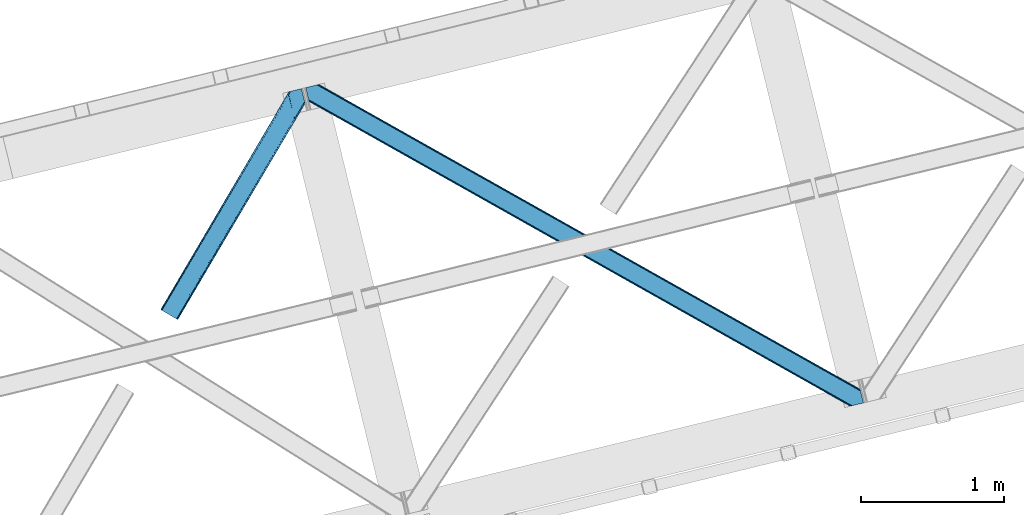
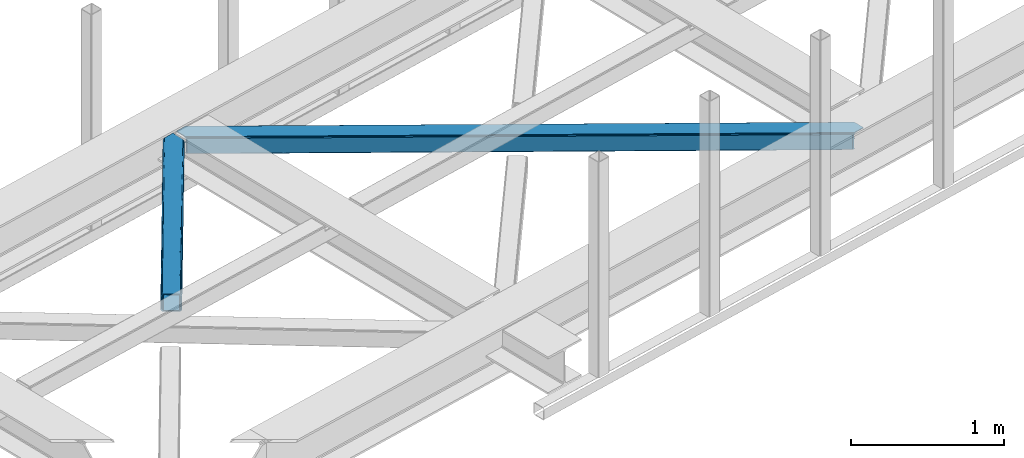
# One storey, part 26 of 66: 2 members.
"""IFC4 building model written with IfcOpenShell, lengths in millimetres."""

from ifc_helpers import new_model, entity, si_unit, converted_unit, derived_unit, direction, frame, origin, place, context, subcontext, project, spatial, triangles, type_object, element, save


model = new_model("IFC4")

# Units and contexts
model_context = context("Model", 3, precision=0.01, world=origin(), true_north=direction((6.12303176911189e-17, 1.0)))
plan_context = context("Plan", 3, precision=0.01, world=origin(), true_north=direction((6.12303176911189e-17, 1.0)))
body_context = subcontext(model_context, "Body", "Model", "MODEL_VIEW")
ifc_project = project(units=[si_unit("LENGTHUNIT", "METRE", prefix="MILLI"), si_unit("AREAUNIT", "SQUARE_METRE"), si_unit("VOLUMEUNIT", "CUBIC_METRE"), converted_unit("PLANEANGLEUNIT", "DEGREE", entity("IfcRatioMeasure", 0.0174532925199433), si_unit("PLANEANGLEUNIT", "RADIAN"), dimensions=[0, 0, 0, 0, 0, 0, 0]), si_unit("MASSUNIT", "GRAM", prefix="KILO"), derived_unit("MASSDENSITYUNIT", [(si_unit("MASSUNIT", "GRAM", prefix="KILO"), 1), (si_unit("LENGTHUNIT", "METRE"), -3)]), derived_unit("MOMENTOFINERTIAUNIT", [(si_unit("LENGTHUNIT", "METRE"), 4)]), si_unit("TIMEUNIT", "SECOND"), si_unit("FREQUENCYUNIT", "HERTZ"), si_unit("THERMODYNAMICTEMPERATUREUNIT", "DEGREE_CELSIUS"), derived_unit("THERMALTRANSMITTANCEUNIT", [(si_unit("MASSUNIT", "GRAM", prefix="KILO"), 1), (si_unit("THERMODYNAMICTEMPERATUREUNIT", "KELVIN"), -1), (si_unit("TIMEUNIT", "SECOND"), -3)]), derived_unit("VOLUMETRICFLOWRATEUNIT", [(si_unit("LENGTHUNIT", "METRE"), 3), (si_unit("TIMEUNIT", "SECOND"), -1)]), derived_unit("MASSFLOWRATEUNIT", [(si_unit("MASSUNIT", "GRAM", prefix="KILO"), 1), (si_unit("TIMEUNIT", "SECOND"), -1)]), derived_unit("ROTATIONALFREQUENCYUNIT", [(si_unit("TIMEUNIT", "SECOND"), -1)]), si_unit("ELECTRICCURRENTUNIT", "AMPERE"), si_unit("ELECTRICVOLTAGEUNIT", "VOLT"), si_unit("POWERUNIT", "WATT"), si_unit("FORCEUNIT", "NEWTON", prefix="KILO"), si_unit("ILLUMINANCEUNIT", "LUX"), si_unit("LUMINOUSFLUXUNIT", "LUMEN"), si_unit("LUMINOUSINTENSITYUNIT", "CANDELA"), derived_unit("USERDEFINED", [(si_unit("MASSUNIT", "GRAM", prefix="KILO"), -1), (si_unit("LENGTHUNIT", "METRE"), -2), (si_unit("TIMEUNIT", "SECOND"), 3), (si_unit("LUMINOUSFLUXUNIT", "LUMEN"), 1)]), derived_unit("LINEARVELOCITYUNIT", [(si_unit("LENGTHUNIT", "METRE"), 1), (si_unit("TIMEUNIT", "SECOND"), -1)]), si_unit("PRESSUREUNIT", "PASCAL"), derived_unit("USERDEFINED", [(si_unit("LENGTHUNIT", "METRE"), -2), (si_unit("MASSUNIT", "GRAM", prefix="KILO"), 1), (si_unit("TIMEUNIT", "SECOND"), -2)]), derived_unit("LINEARFORCEUNIT", [(si_unit("MASSUNIT", "GRAM", prefix="KILO"), 1), (si_unit("LENGTHUNIT", "METRE"), 1), (si_unit("TIMEUNIT", "SECOND"), -2), (si_unit("LENGTHUNIT", "METRE"), -1)]), derived_unit("PLANARFORCEUNIT", [(si_unit("MASSUNIT", "GRAM", prefix="KILO"), 1), (si_unit("LENGTHUNIT", "METRE"), 1), (si_unit("TIMEUNIT", "SECOND"), -2), (si_unit("LENGTHUNIT", "METRE"), -2)])], contexts=[model_context, plan_context])

# Site, building, storey
site_placement = place(None, origin())
site = spatial("IfcSite", under=ifc_project, at=site_placement, CompositionType="ELEMENT")
building_placement = place(site_placement, origin())
building = spatial("IfcBuilding", under=site, at=building_placement, CompositionType="ELEMENT")
storey_placement = place(building_placement, frame((0.0, 0.0, 19800.0)))
storey = spatial("IfcBuildingStorey", under=building, at=storey_placement, Name="06", CompositionType="ELEMENT", Elevation=19800.0)

# Members
member_type_1 = type_object("IfcMemberType", PredefinedType="BRACE")
member_1_placement = place(storey_placement, frame((-49332.88, 6520.94, 3824.0)))
element("IfcMember", 1, at=member_1_placement, inside=storey, type_object=member_type_1, ObjectType="Steel Horizontal Brace", PredefinedType="BRACE", context=body_context, shape_type="Tessellation", body=[
    triangles([(3809.33957519531, 0.0, 122.499499511719), (3811.23713378907, 0.462181091308594, 129.196765136719), (23.4590332031294, 2133.5476776123, 129.196765136719), (23.8915649414048, 2131.77569274902, 122.499499511719), (3816.63215332032, 1.7772171020506, 134.87548828125), (22.2265502929731, 2138.59446258545, 134.87548828125), (3824.70607910156, 3.74512023925763, 138.668280029298), (20.3894531250044, 2146.14690856934, 138.668280029298), (3834.23107910156, 6.06707153320258, 140.00075683594), (18.2174926757798, 2155.05566711426, 140.00075683594), (1916.9806640625, 1065.68146362305, 17.5012573242202), (2556.1183959961, 705.752851867675, 17.5012573242202), (3195.25147705078, 345.824240112304, 17.5012573242202), (3809.33957519531, 0.0, 17.5012573242202), (1277.84758300782, 1425.61065673828, 17.5012573242202), (638.709851074222, 1785.53868713379, 17.5012573242202), (23.8915649414048, 2131.77569274902, 17.5012573242202), (3885.46051025391, 97.721360778808, 140.00075683594), (3903.67800292969, 22.9951080322262, 140.00075683594), (69.4469238281235, 2246.70995635986, 140.00075683594), (0.0, 2229.78191986084, 140.00075683594), (3883.28854980469, 106.63011932373, 138.668280029298), (78.971923828125, 2249.03190765381, 138.668280029298), (3881.44680175781, 114.182565307617, 134.87548828125), (87.0458496093779, 2251.00039215088, 134.87548828125), (3880.21896972656, 119.229350280762, 129.196765136719), (92.4408691406279, 2252.31542816162, 129.196765136719), (3879.78643798828, 121.001335144043, 122.499499511719), (94.3384277343794, 2252.77760925293, 122.499499511719), (3265.41928710938, 466.982542419433, 17.5012573242202), (3879.78643798828, 121.001335144043, 17.5012573242202), (2626.2955078125, 826.905340576172, 17.5012573242202), (1987.17172851563, 1186.82813873291, 17.5012573242202), (708.924169921876, 1906.67315368652, 17.5012573242202), (94.3384277343794, 2252.77760925293, 17.5012573242202), (1348.04794921875, 1546.75093688965, 17.5012573242202), (77.0929687500029, 2248.57321472168, 127.873590087893), (69.0143920898481, 2246.60473022461, 131.668707275392), (82.4879882812529, 2249.88883209228, 122.197192382813), (59.4893920898467, 2244.28277893066, 133.001184082033), (0.0, 2229.78191986084, 133.001184082033), (84.3808959960952, 2250.35043182373, 115.499926757813), (84.3808959960952, 2250.35043182373, 24.5008300781265), (82.4879882812529, 2249.88883209228, 17.8035644531265), (92.0548461914077, 2252.22124786377, 10.8691040039084), (91.5851074218735, 2252.10613861084, 9.49942016601563), (77.0929687500029, 2248.57321472168, 12.1248413085959), (72.3118652343765, 2247.40816955566, 9.49942016601563), (1983.48823242188, 1180.86745605469, 24.5008300781265), (3882.05606689453, 111.689694213866, 115.499926757813), (2626.78850097657, 818.593057250976, 24.5008300781265), (3270.08876953125, 456.319239807129, 24.5008300781265), (3882.05606689453, 111.689694213866, 24.5008300781265), (1340.18796386719, 1543.14127349854, 24.5008300781265), (696.892346191409, 1905.41509094238, 24.5008300781265), (3882.48859863282, 109.917127990722, 122.197192382813), (3883.71643066406, 104.870924377441, 127.873590087893), (3885.55817871094, 97.318478393554, 131.668707275392), (3887.73013916016, 88.4097198486324, 133.001184082033), (3883.71643066406, 104.870924377441, 12.1248413085959), (3885.41865234375, 97.8998382568352, 8.52041015625218), (3880.59104003906, 117.702699279785, 8.52041015625218), (3903.67800292969, 22.9951080322262, 133.001184082033), (3882.48859863282, 109.917127990722, 17.8035644531265), (3880.37244873047, 118.590435791015, 10.9365417480476), (3844.18861083985, 8.4942489624018, 133.001184082033), (15.9478637695356, 2164.3678894043, 133.001184082033), (3834.66361083985, 6.17229766845685, 131.668707275392), (18.1198242187529, 2155.45854949951, 131.668707275392), (3826.58503417969, 4.20381317138617, 127.873590087893), (19.9569213867217, 2147.90610351563, 127.873590087893), (3821.19001464844, 2.88877716064417, 122.197192382813), (21.1894042968779, 2142.85989990234, 122.197192382813), (3819.2971069336, 2.42717742919922, 115.499926757813), (21.6219360351606, 2141.08791503906, 115.499926757813), (3208.50183105469, 346.39571685791, 24.5008300781265), (3819.2971069336, 2.42717742919922, 24.5008300781265), (2565.16435546875, 708.690463256836, 24.5008300781265), (1921.82687988281, 1070.98520965576, 24.5008300781265), (635.156579589842, 1795.57528381348, 24.5008300781265), (21.6219360351606, 2141.08791503906, 24.5008300781265), (1278.49405517578, 1433.28053741455, 24.5008300781265), (21.1894042968779, 2142.85989990234, 17.8035644531265), (19.9569213867217, 2147.90610351563, 12.1248413085959), (23.263696289061, 2134.3505355835, 9.49942016601563), (23.3706665039063, 2133.90986480713, 10.8691040039084), (18.8686157226548, 2152.37676086426, 9.49942016601563), (3821.19001464844, 2.88877716064417, 17.8035644531265), (3811.91616210937, 0.628450012206486, 10.9365417480476), (3812.86494140625, 0.859831237792605, 8.52041015625218), (3826.58503417969, 4.20381317138617, 12.1248413085959), (3834.04039306641, 6.02056274414008, 8.52041015625218), (190.667431640628, 2055.62743377685, 9.49942016601563), (195.062512207034, 2037.60120849609, 9.49942016601563), (196.076403808598, 2037.6692276001, 8.49948120117188), (196.057800292969, 2037.42389373779, 8.8831787109375), (191.290649414063, 2056.67097473144, 8.85294799804615), (195.732238769531, 2037.48144836426, 9.08316650390771), (191.346459960936, 2055.82567749023, 9.20641479492406), (195.388073730472, 2037.54365386963, 9.29943237304906), (191.006945800786, 2055.72684631348, 9.35291748046802), (191.239489746098, 2057.51627197266, 8.49948120117188), (150.921020507813, 2218.69073638916, 9.49942016601563), (155.316101074219, 2200.6645111084, 9.49942016601563), (151.251232910159, 2218.34947814941, 9.25757446289208), (155.813745117186, 2200.23721160889, 9.42500610351635), (151.60469970703, 2217.98496551514, 8.99945068359375), (156.250927734378, 2199.30529174805, 9.11804809570458), (151.962817382817, 2217.619871521, 8.74132690429906), (156.692761230472, 2198.36407012939, 8.80643920898365), (152.293029785156, 2217.27861328125, 8.49948120117188), (157.129943847656, 2197.43156890869, 8.49948120117188), (3713.61983642578, 194.649165344238, 8.52041015625218), (3708.7922241211, 214.452026367188, 8.52041015625218), (3713.26636962891, 194.529986572265, 8.40181274414135), (3708.39689941407, 214.570623779297, 8.37390747070458), (3713.06173095703, 194.460223388672, 8.3320495605476), (3708.00622558594, 214.689221191406, 8.22740478515698), (3707.90390625, 214.477606201172, 7.87393798828271), (3713.112890625, 193.949789428711, 8.19484863281468), (3707.80623779297, 214.265991210938, 7.52047119140843), (3713.23846435547, 192.705679321289, 7.85765991211156), (3713.36403808594, 191.465057373047, 7.52047119140843), (3264.76351318359, 465.821566772461, 10.8039916992202), (3262.90316162109, 462.516535949707, 5.12526855468968), (3260.11728515625, 457.569744873046, 1.33247680664135), (3708.58293457032, 211.088278198242, 5.59500732422021), (708.268395996092, 1905.51275939941, 10.8039916992202), (706.408044433592, 1902.2071472168, 5.12526855468968), (153.148791503911, 2213.77475738525, 5.12526855468968), (703.622167968751, 1897.26035614014, 1.33247680664135), (154.990539550781, 2206.22231140137, 1.33247680664135), (700.333996582034, 1891.42524719238, 0.0), (157.162499999999, 2197.31355285644, 0.0), (3710.29445800781, 204.051498413086, 1.33247680664135), (3712.46641845704, 195.142739868164, 0.0), (3256.83376464844, 451.73405456543, 0.0), (2625.63973388672, 825.744364929199, 10.8039916992202), (1986.51595458984, 1185.66716308594, 10.8039916992202), (1347.39217529297, 1545.58996124268, 10.8039916992202), (2623.77938232422, 822.439334106445, 5.12526855468968), (1984.65560302734, 1182.36213226318, 5.12526855468968), (1345.53182373047, 1542.28434906006, 5.12526855468968), (2620.99350585938, 817.492543029785, 1.33247680664135), (1981.8697265625, 1177.41475982666, 1.33247680664135), (1342.74594726563, 1537.3375579834, 1.33247680664135), (2617.70998535156, 811.656852722168, 0.0), (1978.58155517578, 1171.57965087891, 0.0), (1339.45777587891, 1531.50244903564, 0.0), (3746.51550292969, 55.4634750366204, 0.0), (3203.83699951172, 361.072146606445, 0.0), (2564.70391845703, 721.000758361816, 0.0), (1925.57083740235, 1080.92995147705, 0.0), (1286.43310546875, 1440.85856323242, 0.0), (647.300024414064, 1800.78717498779, 0.0), (191.206933593749, 2057.6342880249, 0.0), (3195.90725097656, 346.984634399414, 10.8039916992202), (639.365624999999, 1786.69966278076, 10.8039916992202), (641.225976562499, 1790.00527496338, 5.12526855468968), (195.220642089844, 2041.17308349609, 5.12526855468968), (3197.76760253906, 350.290246582031, 5.12526855468968), (3200.55347900391, 355.237037658691, 1.33247680664135), (3748.6874633789, 46.5547164916989, 1.33247680664135), (3752.58024902344, 34.8100845336912, 8.52041015625218), (3750.40363769532, 39.517936706543, 5.59500732422021), (3751.18033447266, 36.3402236938473, 7.52047119140843), (3752.24073486328, 35.1804107666012, 8.278564453125), (644.011853027347, 1794.95206604004, 1.33247680664135), (193.378894042973, 2048.72552947998, 1.33247680664135), (2561.41574707031, 715.165649414063, 1.33247680664135), (1922.28266601563, 1075.09426116943, 1.33247680664135), (1283.14958496094, 1435.02345428467, 1.33247680664135), (2558.62987060547, 710.218858337402, 5.12526855468968), (1919.49678955078, 1070.14747009277, 5.12526855468968), (1280.36370849609, 1430.07666320801, 5.12526855468968), (2556.76951904297, 706.913246154785, 10.8039916992202), (1917.63643798828, 1066.84243927002, 10.8039916992202), (1278.49870605469, 1426.77105102539, 10.8039916992202), (3745.61788330078, 59.1411575317379, 7.52047119140843), (3746.13413085938, 57.3430114746088, 7.90416870117406), (3746.6736328125, 56.4360900878901, 8.10880737304615), (3747.30150146485, 55.3762710571282, 8.34832763671875), (3747.75263671875, 54.6129455566406, 8.52041015625218), (3211.01795654297, 350.861723327636, 12.1248413085959), (3217.08735351563, 361.644204711914, 6.99957275390625), (3213.80383300781, 355.808514404296, 8.3320495605476), (3744.24587402344, 64.7751159667969, 6.99957275390625), (643.742102050783, 1810.82377166748, 6.99957275390625), (188.937304687504, 2066.94651031494, 6.99957275390625), (637.672705078126, 1800.0412902832, 12.1248413085959), (640.458581542967, 1804.98866271973, 8.3320495605476), (635.807702636717, 1796.73625946045, 17.8035644531265), (3209.15760498047, 347.556111145019, 17.8035644531265), (2565.82012939453, 709.851438903808, 17.8035644531265), (1922.4826538086, 1072.14618530273, 17.8035644531265), (1279.14517822266, 1434.44093170166, 17.8035644531265), (2567.68048095703, 713.156469726562, 12.1248413085959), (1924.3430053711, 1075.45179748535, 12.1248413085959), (1281.00552978516, 1437.74654388428, 12.1248413085959), (2570.46635742188, 718.103842163086, 8.3320495605476), (1927.12888183594, 1080.39858856201, 8.3320495605476), (1283.79140625, 1442.69333496094, 8.3320495605476), (2573.7545288086, 723.938951110839, 6.99957275390625), (1930.41705322266, 1086.23369750977, 6.99957275390625), (1287.07957763672, 1448.52902526855, 6.99957275390625), (694.376220703125, 1900.94908447266, 12.1248413085959), (691.590344238284, 1896.002293396, 8.3320495605476), (157.264819335942, 2196.88450927734, 8.41343994140698), (159.43212890625, 2188.00191192627, 6.99957275390625), (3261.50324707032, 441.070751953124, 6.99957275390625), (3264.78676757812, 446.905860900879, 8.3320495605476), (3714.73604736328, 185.831098937988, 6.99957275390625), (3267.57264404297, 451.853233337402, 12.1248413085959), (688.302172851567, 1890.16718444824, 6.99957275390625), (696.236572265625, 1904.25469665527, 17.8035644531265), (3269.43299560547, 455.158264160156, 17.8035644531265), (2618.20297851563, 803.344569396972, 6.99957275390625), (2621.48649902344, 809.179678344726, 8.3320495605476), (1978.18623046875, 1171.45407714844, 8.3320495605476), (1974.90270996094, 1165.61896820068, 6.99957275390625), (1334.89061279297, 1533.72847595215, 8.3320495605476), (1331.60244140625, 1527.89336700439, 6.99957275390625), (2624.27237548828, 814.12705078125, 12.1248413085959), (1980.9767578125, 1176.40144958496, 12.1248413085959), (1337.67648925781, 1538.67526702881, 12.1248413085959), (2626.13272705078, 817.432081604004, 17.8035644531265), (1982.837109375, 1179.70648040771, 17.8035644531265), (1339.53684082031, 1541.98087921143, 17.8035644531265)], [[1, 2, 3], [3, 4, 1], [2, 5, 6], [6, 3, 2], [5, 7, 8], [8, 6, 5], [7, 9, 10], [10, 8, 7], [11, 1, 4], [1, 12, 13], [11, 12, 1], [13, 14, 1], [15, 4, 16], [4, 15, 11], [17, 16, 4], [9, 18, 10], [9, 19, 18], [20, 10, 18], [21, 10, 20], [18, 22, 23], [23, 20, 18], [22, 24, 25], [25, 23, 22], [24, 26, 27], [27, 25, 24], [26, 28, 29], [29, 27, 26], [30, 28, 31], [28, 30, 32], [28, 33, 29], [33, 28, 32], [34, 35, 29], [36, 29, 33], [29, 36, 34], [37, 38, 23], [25, 37, 23], [25, 27, 39], [37, 25, 39], [39, 27, 29], [38, 20, 23], [21, 40, 41], [21, 20, 40], [38, 40, 20], [39, 29, 42], [43, 35, 44], [29, 43, 42], [35, 45, 44], [29, 35, 43], [46, 44, 45], [47, 44, 46], [48, 47, 46], [49, 50, 42], [50, 51, 52], [49, 51, 50], [52, 53, 50], [54, 42, 55], [42, 54, 49], [43, 55, 42], [50, 56, 42], [39, 42, 56], [56, 57, 39], [37, 39, 57], [57, 58, 37], [38, 37, 58], [58, 59, 38], [40, 38, 59], [57, 24, 22], [60, 61, 62], [24, 57, 56], [58, 57, 22], [58, 18, 59], [19, 59, 18], [59, 19, 63], [58, 22, 18], [31, 28, 53], [62, 64, 60], [64, 31, 53], [65, 64, 62], [65, 31, 64], [28, 50, 53], [56, 26, 24], [28, 26, 56], [50, 28, 56], [59, 66, 67], [66, 59, 63], [67, 40, 59], [41, 40, 67], [66, 68, 67], [69, 67, 68], [68, 70, 69], [71, 69, 70], [70, 72, 71], [73, 71, 72], [72, 74, 73], [75, 73, 74], [76, 74, 77], [74, 76, 78], [74, 79, 75], [79, 74, 78], [80, 81, 75], [82, 75, 79], [75, 82, 80], [73, 6, 71], [75, 81, 4], [3, 73, 4], [73, 3, 6], [73, 75, 4], [81, 17, 4], [83, 84, 85], [85, 86, 83], [86, 17, 83], [81, 83, 17], [67, 10, 21], [10, 69, 8], [69, 10, 67], [21, 41, 67], [69, 71, 8], [87, 85, 84], [8, 71, 6], [70, 68, 7], [5, 70, 7], [5, 2, 72], [70, 5, 72], [72, 2, 1], [68, 9, 7], [19, 66, 63], [19, 9, 66], [68, 66, 9], [72, 1, 74], [77, 14, 88], [1, 77, 74], [14, 89, 88], [1, 14, 77], [90, 88, 89], [91, 88, 90], [92, 91, 90], [93, 94, 85], [85, 87, 93], [95, 96, 97], [96, 98, 99], [99, 98, 100], [101, 100, 94], [94, 93, 101], [100, 101, 99], [99, 97, 96], [97, 102, 95], [103, 104, 46], [48, 46, 104], [105, 106, 104], [107, 108, 106], [109, 110, 108], [111, 112, 110], [110, 109, 111], [108, 107, 109], [106, 105, 107], [104, 103, 105], [62, 61, 113], [113, 114, 62], [115, 116, 114], [117, 118, 116], [116, 115, 117], [119, 118, 120], [121, 119, 122], [122, 123, 121], [120, 122, 119], [117, 120, 118], [114, 113, 115], [124, 30, 31], [125, 124, 118], [118, 119, 125], [119, 121, 125], [124, 65, 114], [114, 116, 124], [116, 118, 124], [65, 62, 114], [126, 125, 127], [45, 128, 103], [128, 129, 130], [130, 111, 128], [128, 109, 107], [109, 128, 111], [128, 105, 103], [105, 128, 107], [128, 45, 35], [35, 34, 128], [103, 46, 45], [129, 131, 132], [132, 130, 129], [131, 133, 134], [134, 132, 131], [135, 136, 137], [137, 126, 135], [127, 135, 126], [121, 127, 125], [31, 65, 124], [30, 124, 138], [138, 32, 30], [32, 138, 139], [139, 33, 32], [33, 139, 36], [140, 36, 139], [36, 140, 34], [128, 34, 140], [124, 125, 138], [141, 138, 125], [138, 141, 139], [142, 139, 141], [139, 142, 143], [143, 140, 139], [140, 143, 129], [129, 128, 140], [125, 126, 144], [144, 141, 125], [141, 144, 145], [145, 142, 141], [142, 145, 143], [146, 143, 145], [143, 146, 129], [131, 129, 146], [126, 137, 147], [147, 144, 126], [144, 147, 148], [148, 145, 144], [145, 148, 149], [149, 146, 145], [146, 149, 131], [133, 131, 149], [136, 150, 151], [137, 151, 147], [151, 137, 136], [148, 152, 153], [152, 147, 151], [148, 147, 152], [133, 149, 154], [153, 149, 148], [149, 153, 154], [155, 133, 154], [156, 133, 155], [134, 133, 156], [157, 89, 14], [158, 16, 17], [159, 96, 95], [158, 86, 94], [94, 159, 158], [94, 98, 159], [86, 85, 94], [95, 160, 159], [161, 162, 163], [89, 157, 164], [157, 161, 165], [165, 166, 157], [167, 164, 157], [157, 166, 167], [164, 90, 89], [163, 165, 161], [150, 163, 162], [162, 151, 150], [155, 168, 169], [169, 156, 155], [168, 159, 160], [160, 169, 168], [17, 86, 158], [14, 13, 157], [151, 162, 170], [170, 152, 151], [152, 170, 153], [171, 153, 170], [153, 171, 154], [172, 154, 171], [154, 172, 155], [168, 155, 172], [162, 161, 170], [173, 170, 161], [170, 173, 171], [174, 171, 173], [171, 174, 172], [175, 172, 174], [172, 175, 168], [159, 168, 175], [161, 157, 176], [176, 173, 161], [173, 176, 177], [177, 174, 173], [174, 177, 178], [178, 175, 174], [175, 178, 158], [158, 159, 175], [157, 13, 176], [12, 176, 13], [176, 12, 177], [11, 177, 12], [177, 11, 178], [15, 178, 11], [178, 15, 158], [16, 158, 15], [166, 179, 180], [166, 180, 181], [167, 181, 182], [167, 182, 183], [92, 90, 183], [164, 183, 90], [184, 183, 182], [91, 92, 183], [183, 184, 91], [185, 180, 179], [182, 185, 186], [182, 181, 185], [180, 185, 181], [179, 187, 185], [188, 189, 102], [93, 84, 190], [93, 87, 84], [102, 190, 191], [190, 102, 97], [97, 99, 190], [80, 192, 81], [83, 81, 192], [192, 190, 83], [84, 83, 190], [102, 191, 188], [182, 186, 184], [88, 91, 184], [184, 193, 88], [77, 88, 193], [193, 76, 77], [76, 193, 194], [194, 78, 76], [78, 194, 79], [195, 79, 194], [79, 195, 82], [196, 82, 195], [82, 196, 192], [192, 80, 82], [193, 184, 194], [197, 194, 184], [194, 197, 195], [198, 195, 197], [195, 198, 199], [199, 196, 195], [196, 199, 190], [190, 192, 196], [184, 186, 200], [200, 197, 184], [197, 200, 201], [201, 198, 197], [198, 201, 202], [202, 199, 198], [199, 202, 191], [191, 190, 199], [186, 185, 203], [203, 200, 186], [200, 203, 201], [204, 201, 203], [201, 204, 202], [205, 202, 204], [202, 205, 191], [188, 191, 205], [206, 106, 108], [108, 207, 206], [108, 110, 207], [110, 208, 207], [104, 206, 47], [47, 48, 104], [207, 208, 209], [210, 123, 122], [122, 211, 210], [122, 117, 211], [210, 212, 123], [213, 211, 117], [61, 60, 113], [213, 113, 60], [209, 214, 207], [206, 215, 44], [44, 47, 206], [215, 55, 43], [43, 44, 215], [64, 53, 216], [52, 216, 53], [60, 64, 213], [216, 213, 64], [210, 211, 217], [218, 217, 211], [217, 218, 219], [219, 220, 217], [220, 219, 221], [221, 222, 220], [222, 221, 207], [207, 214, 222], [211, 213, 223], [223, 218, 211], [218, 223, 224], [224, 219, 218], [219, 224, 221], [225, 221, 224], [221, 225, 207], [206, 207, 225], [213, 216, 223], [226, 223, 216], [223, 226, 224], [227, 224, 226], [224, 227, 225], [228, 225, 227], [225, 228, 215], [215, 206, 225], [216, 52, 51], [51, 226, 216], [226, 51, 227], [49, 227, 51], [227, 49, 228], [54, 228, 49], [228, 54, 215], [55, 215, 54], [209, 134, 189], [132, 208, 130], [208, 132, 134], [130, 208, 111], [134, 209, 208], [189, 134, 156], [169, 102, 156], [102, 169, 160], [156, 102, 189], [160, 95, 102], [136, 212, 187], [123, 127, 121], [136, 123, 212], [123, 135, 127], [123, 136, 135], [150, 136, 187], [179, 150, 187], [165, 179, 166], [179, 163, 150], [179, 165, 163], [203, 185, 210], [210, 217, 203], [217, 204, 203], [204, 217, 220], [185, 212, 210], [185, 187, 212], [214, 188, 222], [188, 214, 189], [209, 189, 214], [205, 222, 188], [220, 205, 204], [222, 205, 220]]),
])
member_type_2 = type_object("IfcMemberType", PredefinedType="BRACE")
member_2_placement = place(storey_placement, frame((-50348.28, 7126.42, 3824.0)))
element("IfcMember", 2, at=member_2_placement, inside=storey, type_object=member_type_2, ObjectType="Steel Horizontal Brace", PredefinedType="BRACE", context=body_context, shape_type="Tessellation", body=[
    triangles([(105.565649414064, 8.87852783203198, 0.0), (15.0828002929702, 62.1485321044929, 0.0), (892.847827148435, 1346.13992614746, 0.0), (857.170935058595, 1492.50308532715, 0.0), (854.896655273435, 1501.83798065186, 1.33247680664135), (9.31105957031104, 65.5459991455082, 1.33247680664135), (852.966540527341, 1509.7520324707, 5.12526855468968), (4.4183349609375, 68.4266372680668, 5.12526855468968), (851.678247070311, 1515.03950042725, 10.8039916992202), (1.14876708984229, 70.3509384155277, 10.8039916992202), (851.222460937497, 1516.89636383057, 17.5012573242202), (0.0, 71.027059936524, 17.5012573242202), (893.638476562497, 1342.89826354981, 0.155804443358647), (111.337390136716, 5.48106079101581, 1.33247680664135), (899.559045410155, 1344.34178009033, 1.33247680664135), (912.390820312496, 1347.47007751465, 10.8039916992202), (914.195361328122, 1347.90958557129, 17.5012573242202), (120.643798828125, 0.0, 17.5012573242202), (119.499682617185, 0.676121520996276, 10.8039916992202), (907.251599121089, 1346.21724700928, 5.12526855468968), (116.230114746089, 2.60042266845721, 5.12526855468968), (902.498400878903, 1345.05743408203, 17.9802978515618), (893.638476562497, 1342.89826354981, 9.69243164062573), (897.768457031249, 1343.90517883301, 12.1248413085959), (903.726232910158, 1345.35683441162, 19.5011352539077), (914.195361328122, 1347.90958557129, 19.5011352539077), (1011.61732177734, 1513.38669433594, 19.5011352539077), (1008.98957519531, 1524.16103668213, 19.5011352539077), (1011.61732177734, 1513.38669433594, 122.499499511719), (120.643798828125, 0.0, 122.499499511719), (114.61160888672, 3.5515274047857, 24.5008300781265), (1009.24072265625, 1523.14423828125, 24.5008300781265), (113.462841796871, 4.22706756591833, 17.8035644531265), (110.197924804685, 6.15195007324292, 12.1248413085959), (105.305200195311, 9.03200683593786, 8.3320495605476), (99.5334594726519, 12.4294738769531, 6.99957275390625), (892.685046386716, 1346.80035095215, 8.8831787109375), (890.471228027345, 1355.89747009277, 6.99957275390625), (21.114990234375, 58.5975860595709, 6.99957275390625), (859.547534179685, 1482.74496002197, 6.99957275390625), (853.961828613283, 1505.66042175293, 18.501196289064), (851.222460937497, 1516.89636383057, 18.501196289064), (854.096704101561, 1505.10929260254, 17.8803039550803), (855.343139648438, 1499.99448852539, 12.1248413085959), (857.273254394531, 1492.08043670654, 8.3320495605476), (1009.24072265625, 1523.14423828125, 115.499926757813), (114.61160888672, 3.5515274047857, 115.499926757813), (1008.78493652344, 1525.00110168457, 122.197192382813), (113.462841796871, 4.22706756591833, 122.197192382813), (1007.49664306641, 1530.28915100098, 127.873590087893), (110.197924804685, 6.15195007324292, 127.873590087893), (1005.57117919921, 1538.20320281983, 131.668707275392), (105.305200195311, 9.03200683593786, 131.668707275392), (1003.29224853515, 1547.53809814453, 133.001184082033), (99.5334594726519, 12.4294738769531, 133.001184082033), (851.952648925777, 1518.13291625977, 19.5011352539077), (854.580395507808, 1507.35857391358, 19.5011352539077), (851.780566406247, 1517.84049224854, 19.2639404296897), (854.43156738281, 1506.95045928955, 19.2592895507805), (851.589880371095, 1517.5149307251, 19.0011657714858), (854.268786621091, 1506.50978851318, 19.0011657714858), (851.394543457027, 1517.1887878418, 18.7360656738274), (854.110656738281, 1506.06853637695, 18.7407165527366), (908.014343261719, 1598.12687072754, 19.5011352539077), (897.545214843747, 1595.57411956787, 19.5011352539077), (1011.16618652343, 1515.24355773926, 129.196765136719), (1009.8778930664, 1520.53160705566, 134.87548828125), (1008.43146972656, 1526.45624542236, 138.000878906252), (986.311889648438, 1617.21175231934, 138.000878906252), (986.311889648438, 1617.21175231934, 133.001184082033), (897.545214843747, 1595.57411956787, 122.499499511719), (0.0, 71.027059936524, 122.499499511719), (7.18095703124709, 66.7999923706057, 17.8035644531265), (10.4505249023423, 64.875109863282, 12.1248413085959), (6.03218994140479, 67.4755325317383, 24.5008300781265), (907.028356933595, 1597.88560638428, 24.5008300781265), (15.3432495117158, 61.9950531005861, 8.3320495605476), (908.832897949214, 1598.32569580078, 122.197192382813), (899.349755859374, 1596.01362762451, 129.196765136719), (904.48897705078, 1597.26645812988, 134.87548828125), (930.738537597652, 1603.66548614502, 133.001184082033), (910.246765136719, 1598.67044219971, 138.000878906252), (921.664672851563, 1601.45341186523, 131.668707275392), (913.972119140621, 1599.57852630615, 127.873590087893), (907.028356933595, 1597.88560638428, 115.499926757813), (21.114990234375, 58.5975860595709, 133.001184082033), (6.03218994140479, 67.4755325317383, 115.499926757813), (15.3432495117158, 61.9950531005861, 131.668707275392), (10.4505249023423, 64.875109863282, 127.873590087893), (7.18095703124709, 66.7999923706057, 122.197192382813), (119.499682617185, 0.676121520996276, 129.196765136719), (116.230114746089, 2.60042266845721, 134.87548828125), (111.337390136716, 5.48106079101581, 138.668280029298), (105.565649414064, 8.87852783203198, 140.00075683594), (15.0828002929702, 62.1485321044929, 140.00075683594), (9.31105957031104, 65.5459991455082, 138.668280029298), (4.4183349609375, 68.4266372680668, 134.87548828125), (1.14876708984229, 70.3509384155277, 129.196765136719), (896.991760253906, 1576.15611877441, 138.000878906252), (938.18924560547, 1407.14434204102, 138.000878906252), (899.024194335936, 1563.59525756836, 140.00075683594), (897.042919921871, 1571.7232498169, 139.000817871096), (896.801074218747, 1573.1371170044, 138.638049316407), (896.926647949214, 1575.15443572998, 138.212493896484), (896.86153564453, 1574.14170684815, 138.426434326171), (937.477661132813, 1407.08620605469, 138.293884277344), (937.082336425781, 1408.09544677734, 138.647351074218), (936.682360839841, 1409.1046875, 139.000817871096), (934.701086425783, 1417.23267974854, 140.00075683594)], [[1, 2, 3], [4, 3, 2], [5, 4, 6], [2, 6, 4], [7, 5, 8], [6, 8, 5], [9, 7, 10], [8, 10, 7], [11, 9, 12], [10, 12, 9], [1, 3, 13], [13, 14, 1], [13, 15, 14], [16, 17, 18], [18, 19, 16], [20, 16, 19], [19, 21, 20], [15, 20, 21], [21, 14, 15], [20, 22, 16], [23, 24, 15], [23, 15, 13], [15, 24, 20], [16, 25, 17], [20, 24, 22], [16, 22, 25], [26, 17, 25], [26, 25, 27], [28, 27, 25], [27, 29, 26], [30, 26, 29], [26, 18, 17], [30, 18, 26], [31, 32, 25], [25, 33, 31], [25, 22, 33], [32, 28, 25], [33, 22, 24], [34, 24, 23], [23, 35, 34], [36, 35, 37], [37, 38, 36], [23, 37, 35], [24, 34, 33], [39, 36, 38], [38, 40, 39], [9, 11, 41], [11, 42, 41], [43, 9, 41], [43, 7, 9], [44, 7, 43], [5, 44, 45], [44, 5, 7], [4, 5, 45], [45, 40, 4], [37, 23, 13], [37, 3, 38], [3, 40, 38], [40, 3, 4], [37, 13, 3], [46, 32, 31], [31, 47, 46], [48, 46, 49], [47, 49, 46], [50, 48, 51], [49, 51, 48], [52, 50, 53], [51, 53, 50], [54, 52, 55], [53, 55, 52], [56, 57, 58], [59, 58, 57], [58, 59, 60], [61, 60, 59], [60, 61, 62], [63, 62, 61], [62, 63, 42], [41, 42, 63], [57, 56, 64], [65, 64, 56], [66, 48, 67], [46, 29, 27], [27, 32, 46], [32, 27, 28], [48, 29, 46], [66, 29, 48], [50, 68, 67], [52, 68, 50], [67, 48, 50], [52, 54, 68], [54, 69, 68], [70, 69, 54], [71, 60, 62], [58, 60, 71], [71, 56, 58], [56, 71, 65], [42, 12, 72], [12, 42, 11], [71, 42, 72], [42, 71, 62], [73, 74, 44], [75, 73, 43], [43, 41, 75], [43, 57, 75], [64, 76, 57], [75, 57, 76], [44, 43, 73], [45, 44, 74], [74, 77, 45], [40, 45, 77], [77, 39, 40], [78, 79, 80], [81, 82, 69], [69, 70, 81], [81, 83, 82], [84, 82, 83], [80, 82, 84], [78, 71, 79], [85, 71, 78], [80, 84, 78], [65, 76, 64], [85, 65, 71], [76, 65, 85], [86, 54, 55], [54, 86, 81], [70, 54, 81], [76, 85, 87], [87, 75, 76], [83, 81, 86], [86, 88, 83], [84, 83, 88], [88, 89, 84], [78, 84, 89], [89, 90, 78], [85, 78, 90], [90, 87, 85], [91, 51, 49], [47, 18, 30], [91, 49, 30], [91, 92, 51], [49, 47, 30], [51, 92, 93], [55, 94, 95], [94, 53, 93], [53, 94, 55], [53, 51, 93], [19, 34, 21], [31, 18, 47], [18, 33, 19], [33, 18, 31], [19, 33, 34], [1, 36, 2], [14, 21, 34], [34, 35, 14], [35, 36, 1], [1, 14, 35], [89, 96, 97], [95, 86, 55], [95, 88, 86], [88, 95, 96], [89, 88, 96], [87, 72, 12], [98, 90, 89], [97, 98, 89], [90, 98, 72], [87, 90, 72], [6, 74, 8], [2, 36, 39], [39, 77, 2], [77, 74, 6], [6, 2, 77], [10, 8, 74], [12, 75, 87], [73, 12, 10], [12, 73, 75], [73, 10, 74], [99, 68, 82], [99, 100, 68], [68, 69, 82], [96, 95, 101], [101, 102, 96], [97, 96, 103], [104, 97, 105], [104, 99, 97], [97, 103, 105], [82, 80, 99], [97, 99, 80], [102, 103, 96], [79, 71, 98], [72, 98, 71], [80, 79, 97], [98, 97, 79], [92, 67, 100], [100, 93, 92], [67, 68, 100], [106, 107, 93], [94, 93, 107], [107, 108, 94], [108, 109, 94], [66, 67, 92], [92, 91, 66], [29, 66, 91], [91, 30, 29], [95, 94, 109], [109, 101, 95], [107, 103, 102], [105, 103, 107], [106, 104, 105], [100, 99, 104], [107, 106, 105], [102, 108, 107], [102, 101, 109], [109, 108, 102]]),
])

save(model, "model.ifc")
